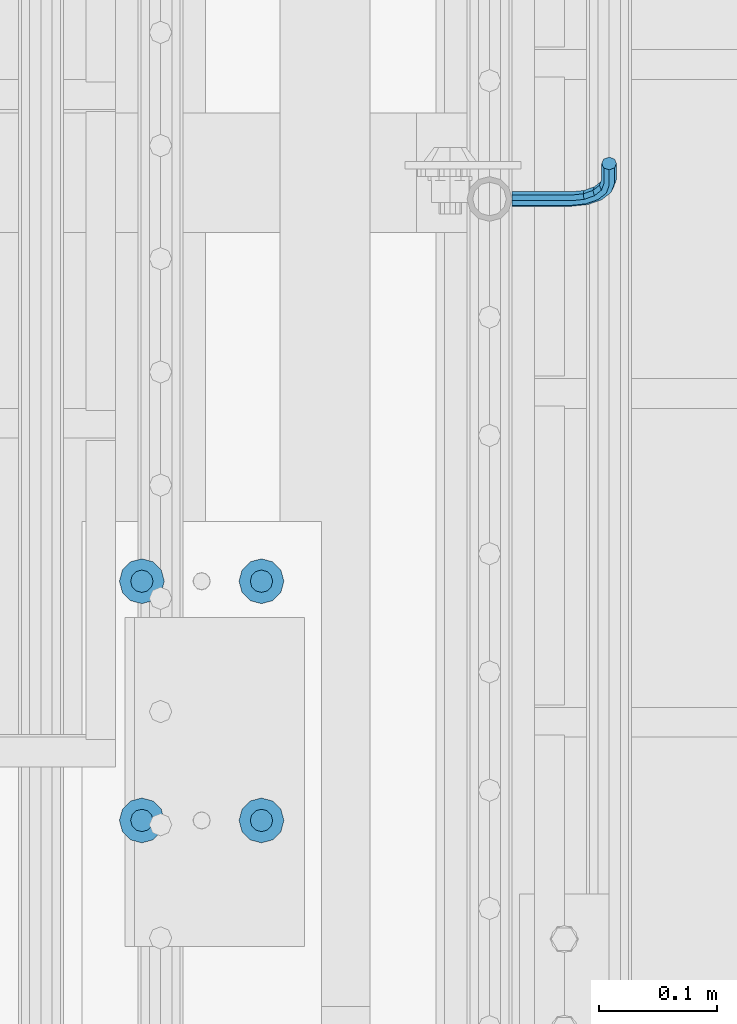
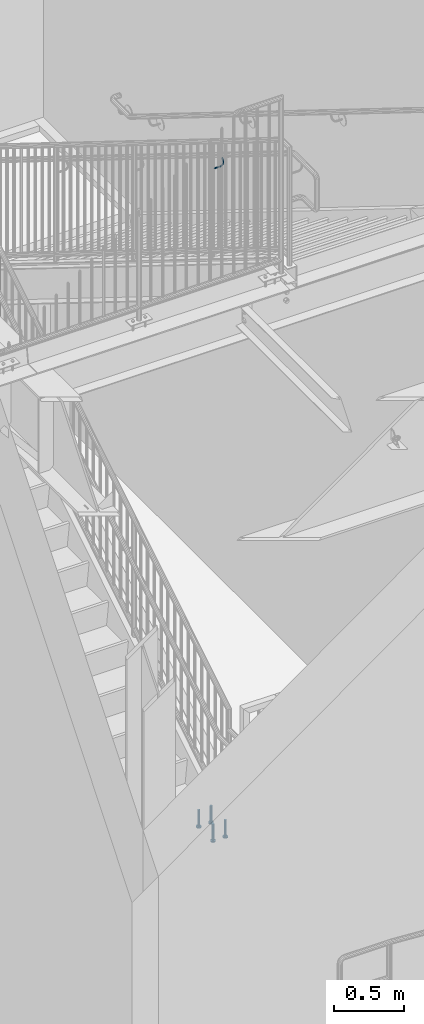
# One storey, part 1261 of 1763: 5 beams, 2 elements without a shape of their own.
"""IFC2X3 building model written with IfcOpenShell, lengths in millimetres."""

from ifc_helpers import new_model, si_unit, frame, origin_with_axes, place, context, subcontext, project, spatial, faceted_brep, material, type_object, element, aggregate, save


model = new_model("IFC2X3")

# Units and contexts
model_context = context("Model", 3, precision=1e-05, world=origin_with_axes())
body_context = subcontext(model_context, "Body", "Model", "MODEL_VIEW")
ifc_project = project(units=[si_unit("LENGTHUNIT", "METRE", prefix="MILLI"), si_unit("AREAUNIT", "SQUARE_METRE"), si_unit("VOLUMEUNIT", "CUBIC_METRE"), si_unit("MASSUNIT", "GRAM", prefix="KILO"), si_unit("TIMEUNIT", "SECOND"), si_unit("PLANEANGLEUNIT", "RADIAN"), si_unit("SOLIDANGLEUNIT", "STERADIAN"), si_unit("THERMODYNAMICTEMPERATUREUNIT", "DEGREE_CELSIUS"), si_unit("LUMINOUSINTENSITYUNIT", "LUMEN")], contexts=[model_context])

# Site, building, storey
site_placement = place(None, origin_with_axes())
site = spatial("IfcSite", under=ifc_project, at=site_placement, CompositionType="ELEMENT")
building_placement = place(site_placement, origin_with_axes())
building = spatial("IfcBuilding", under=site, at=building_placement, Name="Undefined", CompositionType="ELEMENT")
storey_placement = place(building_placement, origin_with_axes())
storey = spatial("IfcBuildingStorey", under=building, at=storey_placement, Name="Undefined", CompositionType="ELEMENT", Elevation=0.0)

# Assembly, beam
assembly_1_placement = place(storey_placement, origin_with_axes())
assembly_1 = element("IfcElementAssembly", 1, at=assembly_1_placement, inside=storey, Name="RAIL", AssemblyPlace="NOTDEFINED", PredefinedType="RIGID_FRAME")
ifc_material_1 = material(Name="STEEL/A36")
beam_type_1 = type_object("IfcBeamType", PredefinedType="NOTDEFINED")
beam_1_placement = place(assembly_1_placement, frame((-85260.8221005486, 32778.6999998061, 5543.71170187482), z_axis=(0.0, -0.849585467029397, 0.527450978018281), x_axis=(1.0, 0.0, 0.0)))
beam_1 = element("IfcBeam", 2, at=beam_1_placement, type_object=beam_type_1, material=ifc_material_1, Name="RAIL", context=body_context, shape_type="Brep", body=[
    faceted_brep([(0.0, -6.34999999999491, 1.45519152283669e-11), (-1.13686837721616e-13, -4.49012806053361, -4.49012806058454), (50.8000030517578, -4.49012806053452, -4.49012806053361), (50.8000030517578, -6.35000000000036, 0.0), (0.0, 0.0, -6.34999990463257), (50.8000030517578, 0.0, -6.34999999999854), (0.0, 4.49012806054088, -4.49012806053452), (50.8000030517578, 4.49012806053452, -4.49012806053361), (0.0, 6.34999999999491, -2.91038304567337e-11), (50.8000030517578, 6.35000000000036, 0.0), (0.0, 4.49012806054088, 4.49012806053452), (50.8000030517578, 4.49012806053452, 4.49012806053361), (0.0, 0.0, 6.34999990463257), (50.8000030517578, 0.0, 6.34999999999854), (0.0, -4.49012806053361, 4.49012806055543), (50.8000030517578, -4.49012806053452, 4.49012806053361), (65.380241824867, -3.44981018867929, 0.0), (64.6684996473195, -1.73151257071549, 4.49012806053361), (62.9502020293439, 2.4168248427668, 6.34999999999854), (61.2319044113829, 6.5651622562491, 4.49012806053361), (60.5201622338354, 8.2834598742138, 0.0), (61.2319044113829, 6.5651622562491, -4.49012806053361), (62.9502020293439, 2.4168248427668, -6.34999999999854), (64.6684996473195, -1.73151257071549, -4.49012806053361), (76.425643354436, 6.12435969732724, -4.49012806053361), (77.7407714149595, 4.8092316367929, 0.0), (73.2506433544331, 9.29935969732742, -6.34999999999854), (70.0756433544302, 12.4743596973276, -4.49012806053361), (68.7605152938922, 13.7894877578619, 0.0), (70.0756433544302, 12.4743596973276, 4.49012806053361), (73.2506433544331, 9.29935969732742, 6.34999999999854), (76.425643354436, 6.12435969732724, 4.49012806053361), (84.2815156224679, 17.8815034044446, -4.49012806053361), (85.9998132404435, 17.1697612268908, 0.0), (80.1331782089983, 19.5998010224093, -6.34999999999854), (75.9848407955142, 21.3180986403731, -4.49012806053361), (74.2665431775386, 22.0298408179269, 0.0), (75.9848407955142, 21.3180986403731, 4.49012806053361), (80.1331782089983, 19.5998010224093, 6.34999999999854), (84.2815156224679, 17.8815034044446, 4.49012806053361), (87.0401311122987, 31.75, -4.49012806053361), (88.9000030517636, 31.75, 0.0), (82.5500030517578, 31.75, -6.34999999999854), (78.0598749912169, 31.75, -4.49012806053361), (76.200003051752, 31.75, 0.0), (78.0598749912169, 31.75, 4.49012806053361), (82.5500030517578, 31.75, 6.34999999999854), (87.0401311122987, 31.75, 4.49012806053361), (87.0401311122987, 57.1500015258789, -4.49012806053361), (88.9000030517636, 57.1500015258789, 0.0), (82.5500030517578, 57.1500015258789, -6.34999999999854), (78.0598749912169, 57.1500015258789, -4.49012806053361), (76.200003051752, 57.1500015258789, 0.0), (78.0598749912169, 57.1500015258789, 4.49012806053361), (82.5500030517578, 57.1500015258789, 6.34999999999854), (87.0401311122987, 57.1500015258789, 4.49012806053361)], [[[0, 1, 2, 3]], [[1, 4, 5, 2]], [[4, 6, 7, 5]], [[6, 8, 9, 7]], [[8, 10, 11, 9]], [[10, 12, 13, 11]], [[12, 14, 15, 13]], [[14, 0, 3, 15]], [[14, 12, 10, 8, 6, 4, 1, 0]], [[15, 3, 16, 17]], [[13, 15, 17, 18]], [[11, 13, 18, 19]], [[9, 11, 19, 20]], [[7, 9, 20, 21]], [[5, 7, 21, 22]], [[2, 5, 22, 23]], [[3, 2, 23, 16]], [[23, 24, 25, 16]], [[22, 26, 24, 23]], [[21, 27, 26, 22]], [[20, 28, 27, 21]], [[19, 29, 28, 20]], [[18, 30, 29, 19]], [[17, 31, 30, 18]], [[16, 25, 31, 17]], [[24, 32, 33, 25]], [[26, 34, 32, 24]], [[27, 35, 34, 26]], [[28, 36, 35, 27]], [[29, 37, 36, 28]], [[30, 38, 37, 29]], [[31, 39, 38, 30]], [[25, 33, 39, 31]], [[32, 40, 41, 33]], [[34, 42, 40, 32]], [[35, 43, 42, 34]], [[36, 44, 43, 35]], [[37, 45, 44, 36]], [[38, 46, 45, 37]], [[39, 47, 46, 38]], [[33, 41, 47, 39]], [[41, 40, 48, 49]], [[40, 42, 50, 48]], [[42, 43, 51, 50]], [[43, 44, 52, 51]], [[44, 45, 53, 52]], [[45, 46, 54, 53]], [[46, 47, 55, 54]], [[47, 41, 49, 55]], [[50, 51, 52, 53, 54, 55, 49, 48]]]),
])
aggregate(assembly_1, [beam_1])

# Assembly, beams
assembly_2_placement = place(storey_placement, origin_with_axes())
assembly_2 = element("IfcElementAssembly", 3, at=assembly_2_placement, inside=storey, Name="PLATE", AssemblyPlace="NOTDEFINED", PredefinedType="RIGID_FRAME")
ifc_material_2 = material(Name="STEEL/A108")
beam_type_2 = type_object("IfcBeamType", Name="STUD_3/4-DIA", PredefinedType="NOTDEFINED")
beam_2_placement = place(assembly_2_placement, frame((-85575.2122767855, 32250.7777095314, 285.749960436508), z_axis=(-1.0, 0.0, 0.0), x_axis=(0.0, 0.0, -1.0)))
beam_2 = element("IfcBeam", 4, at=beam_2_placement, type_object=beam_type_2, material=ifc_material_2, Name="BEAM", ObjectType="STUD_3/4-DIA", context=body_context, shape_type="Brep", body=[
    faceted_brep([(0.0, -9.52000045776367, 0.0), (0.0, -8.25, -4.76000022888184), (138.684, -8.25, -4.76000022888184), (138.684, -9.52000045776367, 0.0), (0.0, -4.76000022888184, -8.25), (138.684, -4.76000022888184, -8.25), (0.0, 0.0, -9.52000045776367), (138.684, 0.0, -9.52000045776367), (0.0, 4.76000022888184, -8.25), (138.684, 4.76000022888184, -8.25), (0.0, 8.25, -4.76000022888184), (138.684, 8.25, -4.76000022888184), (0.0, 9.52000045776367, 0.0), (138.684, 9.52000045776367, 0.0), (0.0, 8.25, 4.76000022888184), (138.684, 8.25, 4.76000022888184), (0.0, 4.76000022888184, 8.25), (138.684, 4.76000022888184, 8.25), (0.0, 0.0, 9.52000045776367), (138.684, 0.0, 9.52000045776367), (0.0, -4.76000022888184, 8.25), (138.684, -4.76000022888184, 8.25), (0.0, -8.25, 4.76000022888184), (138.684, -8.25, 4.76000022888184), (140.208, -16.5, -9.52000045776367), (140.208, -19.0499992370605, 0.0), (140.208, -9.52000045776367, -16.5), (140.208, 0.0, -19.0499992370605), (140.208, 9.52000045776367, -16.5), (140.208, 16.5, -9.52000045776367), (140.208, 19.0499992370605, 0.0), (140.208, 16.5, 9.52000045776367), (140.208, 9.52000045776367, 16.5), (140.208, 0.0, 19.0499992370605), (140.208, -9.52000045776367, 16.5), (140.208, -16.5, 9.52000045776367), (152.4, -16.5, -9.52000045776367), (152.4, -19.0499992370605, 0.0), (152.4, -9.52000045776367, -16.5), (152.4, 0.0, -19.0499992370605), (152.4, 9.52000045776367, -16.5), (152.4, 16.5, -9.52000045776367), (152.4, 19.0499992370605, 0.0), (152.4, 16.5, 9.52000045776367), (152.4, 9.52000045776367, 16.5), (152.4, 0.0, 19.0499992370605), (152.4, -9.52000045776367, 16.5), (152.4, -16.5, 9.52000045776367)], [[[0, 1, 2, 3]], [[1, 4, 5, 2]], [[4, 6, 7, 5]], [[6, 8, 9, 7]], [[8, 10, 11, 9]], [[10, 12, 13, 11]], [[12, 14, 15, 13]], [[14, 16, 17, 15]], [[16, 18, 19, 17]], [[18, 20, 21, 19]], [[20, 22, 23, 21]], [[22, 0, 3, 23]], [[22, 20, 18, 16, 14, 12, 10, 8, 6, 4, 1, 0]], [[3, 2, 24, 25]], [[2, 5, 26, 24]], [[5, 7, 27, 26]], [[7, 9, 28, 27]], [[9, 11, 29, 28]], [[11, 13, 30, 29]], [[13, 15, 31, 30]], [[15, 17, 32, 31]], [[17, 19, 33, 32]], [[19, 21, 34, 33]], [[21, 23, 35, 34]], [[23, 3, 25, 35]], [[25, 24, 36, 37]], [[24, 26, 38, 36]], [[26, 27, 39, 38]], [[27, 28, 40, 39]], [[28, 29, 41, 40]], [[29, 30, 42, 41]], [[30, 31, 43, 42]], [[31, 32, 44, 43]], [[32, 33, 45, 44]], [[33, 34, 46, 45]], [[34, 35, 47, 46]], [[35, 25, 37, 47]], [[38, 39, 40, 41, 42, 43, 44, 45, 46, 47, 37, 36]]]),
])
beam_3_placement = place(assembly_2_placement, frame((-85473.6122767855, 32250.7777095314, 285.749960436499), z_axis=(-1.0, 0.0, 0.0), x_axis=(0.0, 0.0, -1.0)))
beam_3 = element("IfcBeam", 5, at=beam_3_placement, type_object=beam_type_2, material=ifc_material_2, Name="BEAM", ObjectType="STUD_3/4-DIA", context=body_context, shape_type="Brep", body=[
    faceted_brep([(0.0, -9.52000045776367, 0.0), (0.0, -8.25, -4.76000022888184), (138.684, -8.25, -4.76000022888184), (138.684, -9.52000045776367, 0.0), (0.0, -4.76000022888184, -8.25), (138.684, -4.76000022888184, -8.25), (0.0, 0.0, -9.52000045776367), (138.684, 0.0, -9.52000045776367), (0.0, 4.76000022888184, -8.25), (138.684, 4.76000022888184, -8.25), (0.0, 8.25, -4.76000022888184), (138.684, 8.25, -4.76000022888184), (0.0, 9.52000045776367, 0.0), (138.684, 9.52000045776367, 0.0), (0.0, 8.25, 4.76000022888184), (138.684, 8.25, 4.76000022888184), (0.0, 4.76000022888184, 8.25), (138.684, 4.76000022888184, 8.25), (0.0, 0.0, 9.52000045776367), (138.684, 0.0, 9.52000045776367), (0.0, -4.76000022888184, 8.25), (138.684, -4.76000022888184, 8.25), (0.0, -8.25, 4.76000022888184), (138.684, -8.25, 4.76000022888184), (140.208, -16.5, -9.52000045776367), (140.208, -19.0499992370605, 0.0), (140.208, -9.52000045776367, -16.5), (140.208, 0.0, -19.0499992370605), (140.208, 9.52000045776367, -16.5), (140.208, 16.5, -9.52000045776367), (140.208, 19.0499992370605, 0.0), (140.208, 16.5, 9.52000045776367), (140.208, 9.52000045776367, 16.5), (140.208, 0.0, 19.0499992370605), (140.208, -9.52000045776367, 16.5), (140.208, -16.5, 9.52000045776367), (152.4, -16.5, -9.52000045776367), (152.4, -19.0499992370605, 0.0), (152.4, -9.52000045776367, -16.5), (152.4, 0.0, -19.0499992370605), (152.4, 9.52000045776367, -16.5), (152.4, 16.5, -9.52000045776367), (152.4, 19.0499992370605, 0.0), (152.4, 16.5, 9.52000045776367), (152.4, 9.52000045776367, 16.5), (152.4, 0.0, 19.0499992370605), (152.4, -9.52000045776367, 16.5), (152.4, -16.5, 9.52000045776367)], [[[0, 1, 2, 3]], [[1, 4, 5, 2]], [[4, 6, 7, 5]], [[6, 8, 9, 7]], [[8, 10, 11, 9]], [[10, 12, 13, 11]], [[12, 14, 15, 13]], [[14, 16, 17, 15]], [[16, 18, 19, 17]], [[18, 20, 21, 19]], [[20, 22, 23, 21]], [[22, 0, 3, 23]], [[22, 20, 18, 16, 14, 12, 10, 8, 6, 4, 1, 0]], [[3, 2, 24, 25]], [[2, 5, 26, 24]], [[5, 7, 27, 26]], [[7, 9, 28, 27]], [[9, 11, 29, 28]], [[11, 13, 30, 29]], [[13, 15, 31, 30]], [[15, 17, 32, 31]], [[17, 19, 33, 32]], [[19, 21, 34, 33]], [[21, 23, 35, 34]], [[23, 3, 25, 35]], [[25, 24, 36, 37]], [[24, 26, 38, 36]], [[26, 27, 39, 38]], [[27, 28, 40, 39]], [[28, 29, 41, 40]], [[29, 30, 42, 41]], [[30, 31, 43, 42]], [[31, 32, 44, 43]], [[32, 33, 45, 44]], [[33, 34, 46, 45]], [[34, 35, 47, 46]], [[35, 25, 37, 47]], [[38, 39, 40, 41, 42, 43, 44, 45, 46, 47, 37, 36]]]),
])
beam_4_placement = place(assembly_2_placement, frame((-85575.2122767855, 32453.9777095314, 285.749960436504), z_axis=(-1.0, 0.0, 0.0), x_axis=(0.0, 0.0, -1.0)))
beam_4 = element("IfcBeam", 6, at=beam_4_placement, type_object=beam_type_2, material=ifc_material_2, Name="BEAM", ObjectType="STUD_3/4-DIA", context=body_context, shape_type="Brep", body=[
    faceted_brep([(0.0, -9.52000045776367, 0.0), (0.0, -8.25, -4.76000022888184), (138.684, -8.25, -4.76000022888184), (138.684, -9.52000045776367, 0.0), (0.0, -4.76000022888184, -8.25), (138.684, -4.76000022888184, -8.25), (0.0, 0.0, -9.52000045776367), (138.684, 0.0, -9.52000045776367), (0.0, 4.76000022888184, -8.25), (138.684, 4.76000022888184, -8.25), (0.0, 8.25, -4.76000022888184), (138.684, 8.25, -4.76000022888184), (0.0, 9.52000045776367, 0.0), (138.684, 9.52000045776367, 0.0), (0.0, 8.25, 4.76000022888184), (138.684, 8.25, 4.76000022888184), (0.0, 4.76000022888184, 8.25), (138.684, 4.76000022888184, 8.25), (0.0, 0.0, 9.52000045776367), (138.684, 0.0, 9.52000045776367), (0.0, -4.76000022888184, 8.25), (138.684, -4.76000022888184, 8.25), (0.0, -8.25, 4.76000022888184), (138.684, -8.25, 4.76000022888184), (140.208, -16.5, -9.52000045776367), (140.208, -19.0499992370605, 0.0), (140.208, -9.52000045776367, -16.5), (140.208, 0.0, -19.0499992370605), (140.208, 9.52000045776367, -16.5), (140.208, 16.5, -9.52000045776367), (140.208, 19.0499992370605, 0.0), (140.208, 16.5, 9.52000045776367), (140.208, 9.52000045776367, 16.5), (140.208, 0.0, 19.0499992370605), (140.208, -9.52000045776367, 16.5), (140.208, -16.5, 9.52000045776367), (152.4, -16.5, -9.52000045776367), (152.4, -19.0499992370605, 0.0), (152.4, -9.52000045776367, -16.5), (152.4, 0.0, -19.0499992370605), (152.4, 9.52000045776367, -16.5), (152.4, 16.5, -9.52000045776367), (152.4, 19.0499992370605, 0.0), (152.4, 16.5, 9.52000045776367), (152.4, 9.52000045776367, 16.5), (152.4, 0.0, 19.0499992370605), (152.4, -9.52000045776367, 16.5), (152.4, -16.5, 9.52000045776367)], [[[0, 1, 2, 3]], [[1, 4, 5, 2]], [[4, 6, 7, 5]], [[6, 8, 9, 7]], [[8, 10, 11, 9]], [[10, 12, 13, 11]], [[12, 14, 15, 13]], [[14, 16, 17, 15]], [[16, 18, 19, 17]], [[18, 20, 21, 19]], [[20, 22, 23, 21]], [[22, 0, 3, 23]], [[22, 20, 18, 16, 14, 12, 10, 8, 6, 4, 1, 0]], [[3, 2, 24, 25]], [[2, 5, 26, 24]], [[5, 7, 27, 26]], [[7, 9, 28, 27]], [[9, 11, 29, 28]], [[11, 13, 30, 29]], [[13, 15, 31, 30]], [[15, 17, 32, 31]], [[17, 19, 33, 32]], [[19, 21, 34, 33]], [[21, 23, 35, 34]], [[23, 3, 25, 35]], [[25, 24, 36, 37]], [[24, 26, 38, 36]], [[26, 27, 39, 38]], [[27, 28, 40, 39]], [[28, 29, 41, 40]], [[29, 30, 42, 41]], [[30, 31, 43, 42]], [[31, 32, 44, 43]], [[32, 33, 45, 44]], [[33, 34, 46, 45]], [[34, 35, 47, 46]], [[35, 25, 37, 47]], [[38, 39, 40, 41, 42, 43, 44, 45, 46, 47, 37, 36]]]),
])
beam_5_placement = place(assembly_2_placement, frame((-85473.6122767855, 32453.9777095314, 285.749960436495), z_axis=(-1.0, 0.0, 0.0), x_axis=(0.0, 0.0, -1.0)))
beam_5 = element("IfcBeam", 7, at=beam_5_placement, type_object=beam_type_2, material=ifc_material_2, Name="BEAM", ObjectType="STUD_3/4-DIA", context=body_context, shape_type="Brep", body=[
    faceted_brep([(0.0, -9.52000045776367, 0.0), (0.0, -8.25, -4.76000022888184), (138.684, -8.25, -4.76000022888184), (138.684, -9.52000045776367, 0.0), (0.0, -4.76000022888184, -8.25), (138.684, -4.76000022888184, -8.25), (0.0, 0.0, -9.52000045776367), (138.684, 0.0, -9.52000045776367), (0.0, 4.76000022888184, -8.25), (138.684, 4.76000022888184, -8.25), (0.0, 8.25, -4.76000022888184), (138.684, 8.25, -4.76000022888184), (0.0, 9.52000045776367, 0.0), (138.684, 9.52000045776367, 0.0), (0.0, 8.25, 4.76000022888184), (138.684, 8.25, 4.76000022888184), (0.0, 4.76000022888184, 8.25), (138.684, 4.76000022888184, 8.25), (0.0, 0.0, 9.52000045776367), (138.684, 0.0, 9.52000045776367), (0.0, -4.76000022888184, 8.25), (138.684, -4.76000022888184, 8.25), (0.0, -8.25, 4.76000022888184), (138.684, -8.25, 4.76000022888184), (140.208, -16.5, -9.52000045776367), (140.208, -19.0499992370605, 0.0), (140.208, -9.52000045776367, -16.5), (140.208, 0.0, -19.0499992370605), (140.208, 9.52000045776367, -16.5), (140.208, 16.5, -9.52000045776367), (140.208, 19.0499992370605, 0.0), (140.208, 16.5, 9.52000045776367), (140.208, 9.52000045776367, 16.5), (140.208, 0.0, 19.0499992370605), (140.208, -9.52000045776367, 16.5), (140.208, -16.5, 9.52000045776367), (152.4, -16.5, -9.52000045776367), (152.4, -19.0499992370605, 0.0), (152.4, -9.52000045776367, -16.5), (152.4, 0.0, -19.0499992370605), (152.4, 9.52000045776367, -16.5), (152.4, 16.5, -9.52000045776367), (152.4, 19.0499992370605, 0.0), (152.4, 16.5, 9.52000045776367), (152.4, 9.52000045776367, 16.5), (152.4, 0.0, 19.0499992370605), (152.4, -9.52000045776367, 16.5), (152.4, -16.5, 9.52000045776367)], [[[0, 1, 2, 3]], [[1, 4, 5, 2]], [[4, 6, 7, 5]], [[6, 8, 9, 7]], [[8, 10, 11, 9]], [[10, 12, 13, 11]], [[12, 14, 15, 13]], [[14, 16, 17, 15]], [[16, 18, 19, 17]], [[18, 20, 21, 19]], [[20, 22, 23, 21]], [[22, 0, 3, 23]], [[22, 20, 18, 16, 14, 12, 10, 8, 6, 4, 1, 0]], [[3, 2, 24, 25]], [[2, 5, 26, 24]], [[5, 7, 27, 26]], [[7, 9, 28, 27]], [[9, 11, 29, 28]], [[11, 13, 30, 29]], [[13, 15, 31, 30]], [[15, 17, 32, 31]], [[17, 19, 33, 32]], [[19, 21, 34, 33]], [[21, 23, 35, 34]], [[23, 3, 25, 35]], [[25, 24, 36, 37]], [[24, 26, 38, 36]], [[26, 27, 39, 38]], [[27, 28, 40, 39]], [[28, 29, 41, 40]], [[29, 30, 42, 41]], [[30, 31, 43, 42]], [[31, 32, 44, 43]], [[32, 33, 45, 44]], [[33, 34, 46, 45]], [[34, 35, 47, 46]], [[35, 25, 37, 47]], [[38, 39, 40, 41, 42, 43, 44, 45, 46, 47, 37, 36]]]),
])
aggregate(assembly_2, [beam_2, beam_3, beam_4, beam_5])

save(model, "model.ifc")
